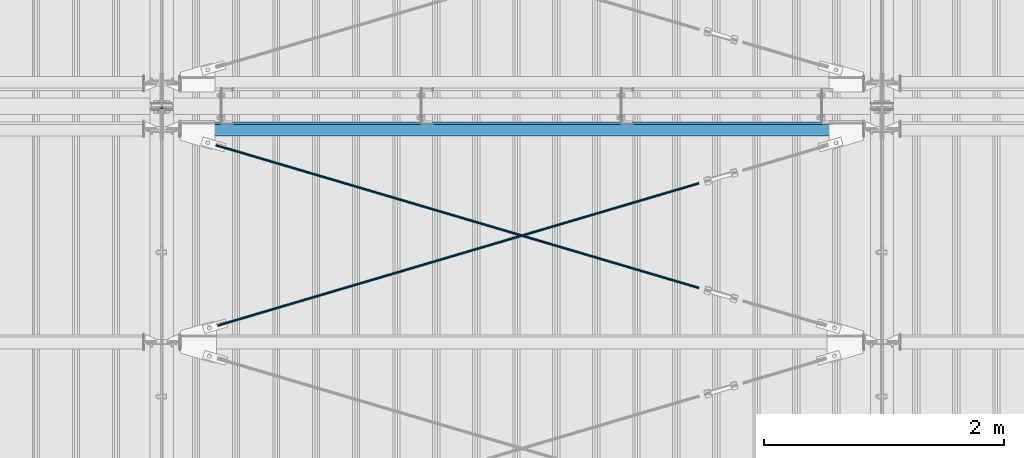
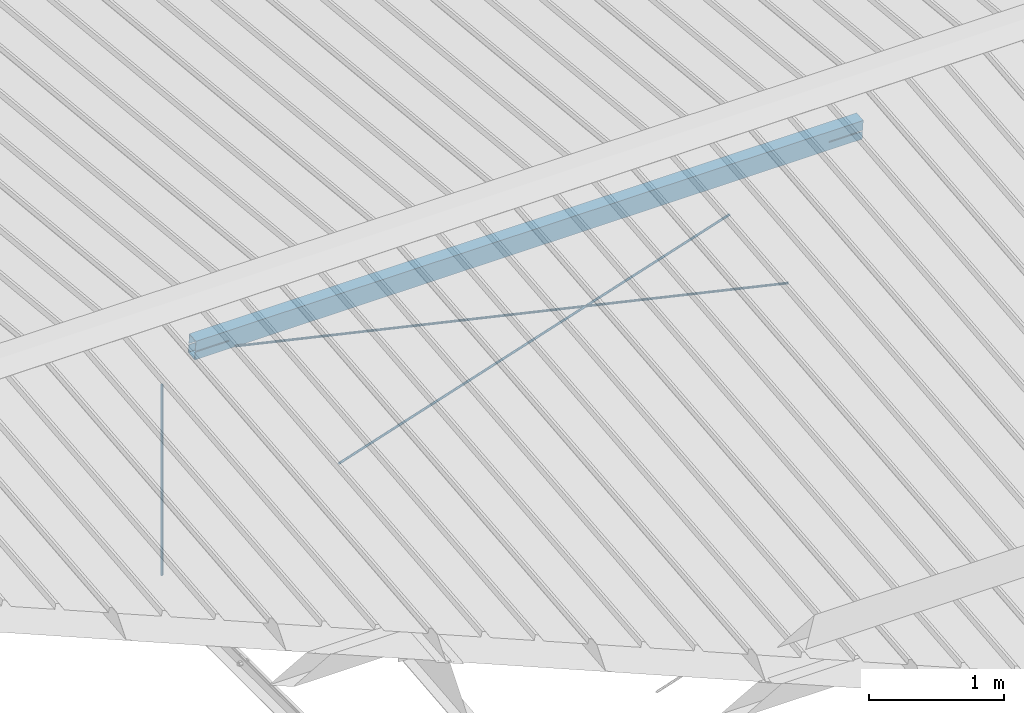
# One storey, part 279 of 709: 4 beams, 4 openings, 4 elements without a shape of their own.
"""IFC4 building model written with IfcOpenShell, lengths in millimetres."""

from ifc_helpers import new_model, si_unit, direction, frame, origin_with_axes, place, context, subcontext, project, spatial, line, indexed_curve, outline, extrude, polygons, material, element, aggregate, save


model = new_model("IFC4")

# Units and contexts
model_context = context("Model", 3, precision=0.2, world=origin_with_axes(), true_north=direction((0.0, 1.0)))
body_context = subcontext(model_context, "Body", "Model", "MODEL_VIEW")
reference_context = subcontext(model_context, "Reference", "Model", "MODEL_VIEW")
ifc_project = project(units=[si_unit("LENGTHUNIT", "METRE", prefix="MILLI"), si_unit("AREAUNIT", "SQUARE_METRE"), si_unit("VOLUMEUNIT", "CUBIC_METRE"), si_unit("MASSUNIT", "GRAM", prefix="KILO"), si_unit("TIMEUNIT", "SECOND"), si_unit("PLANEANGLEUNIT", "RADIAN"), si_unit("SOLIDANGLEUNIT", "STERADIAN"), si_unit("THERMODYNAMICTEMPERATUREUNIT", "DEGREE_CELSIUS"), si_unit("LUMINOUSINTENSITYUNIT", "LUMEN")], contexts=[model_context])

# Site, building, storey
site_placement = place(None, origin_with_axes())
site = spatial("IfcSite", under=ifc_project, at=site_placement, CompositionType="ELEMENT")
building_placement = place(site_placement, origin_with_axes())
building = spatial("IfcBuilding", under=site, at=building_placement, Name="Undefined", CompositionType="ELEMENT")
storey_placement = place(building_placement, origin_with_axes())
storey = spatial("IfcBuildingStorey", under=building, at=storey_placement, Name="Undefined", CompositionType="ELEMENT", Elevation=0.0)

# Assembly, beam
assembly_1_placement = place(storey_placement, frame((40000.0, 10985.0, 8155.10002), z_axis=(0.0, -1.0, 0.0), x_axis=(0.0, 0.0, -1.0)))
assembly_1 = element("IfcElementAssembly", 1, at=assembly_1_placement, inside=storey)
ifc_material_1 = material(Name="C355-5", Category="STEEL")
beam_1_placement = place(assembly_1_placement, origin_with_axes())
beam_1 = element("IfcBeam", 2, at=beam_1_placement, material=ifc_material_1, ObjectType="437", context=body_context, shape_type="Tessellation", body=[
    polygons([(326.36285, 0.0, 10.0), (326.36285, -2.58819, 9.65926), (2045.1, -2.58819, 9.65926), (2045.1, 0.0, 10.0), (326.36285, -5.0, 8.66025), (2045.1, -5.0, 8.66025), (326.36285, -7.07107, 7.07107), (2045.1, -7.07107, 7.07107), (326.36285, -8.66025, 5.0), (2045.1, -8.66025, 5.0), (326.36285, -9.65926, 2.58819), (2045.1, -9.65926, 2.58819), (326.36285, -10.0, 0.0), (2045.1, -10.0, 0.0), (326.36285, -9.65926, -2.58819), (2045.1, -9.65926, -2.58819), (326.36285, -8.66025, -5.0), (2045.1, -8.66025, -5.0), (326.36285, -7.07107, -7.07107), (2045.1, -7.07107, -7.07107), (326.36285, -5.0, -8.66025), (2045.1, -5.0, -8.66025), (326.36285, -2.58819, -9.65926), (2045.1, -2.58819, -9.65926), (326.36285, 0.0, -10.0), (2045.1, 0.0, -10.0), (326.36285, 2.58819, -9.65926), (2045.1, 2.58819, -9.65926), (326.36285, 5.0, -8.66025), (2045.1, 5.0, -8.66025), (326.36285, 7.07107, -7.07107), (2045.1, 7.07107, -7.07107), (326.36285, 8.66025, -5.0), (2045.1, 8.66025, -5.0), (326.36285, 9.65926, -2.58819), (2045.1, 9.65926, -2.58819), (326.36285, 10.0, 0.0), (2045.1, 10.0, 0.0), (326.36285, 9.65926, 2.58819), (2045.1, 9.65926, 2.58819), (326.36285, 8.66025, 5.0), (2045.1, 8.66025, 5.0), (326.36285, 7.07107, 7.07107), (2045.1, 7.07107, 7.07107), (326.36285, 5.0, 8.66025), (2045.1, 5.0, 8.66025), (326.36285, 2.58819, 9.65926), (2045.1, 2.58819, 9.65926)], [[[1, 2, 3, 4]], [[2, 5, 6, 3]], [[5, 7, 8, 6]], [[7, 9, 10, 8]], [[9, 11, 12, 10]], [[11, 13, 14, 12]], [[13, 15, 16, 14]], [[15, 17, 18, 16]], [[17, 19, 20, 18]], [[19, 21, 22, 20]], [[21, 23, 24, 22]], [[23, 25, 26, 24]], [[25, 27, 28, 26]], [[27, 29, 30, 28]], [[29, 31, 32, 30]], [[31, 33, 34, 32]], [[33, 35, 36, 34]], [[35, 37, 38, 36]], [[37, 39, 40, 38]], [[39, 41, 42, 40]], [[41, 43, 44, 42]], [[43, 45, 46, 44]], [[45, 47, 48, 46]], [[47, 1, 4, 48]], [[6, 8, 10, 12, 14, 16, 18, 20, 22, 24, 26, 28, 30, 32, 34, 36, 38, 40, 42, 44, 46, 48, 4, 3]], [[47, 45, 43, 41, 39, 37, 35, 33, 31, 29, 27, 25, 23, 21, 19, 17, 15, 13, 11, 9, 7, 5, 2, 1]]], closed=True),
])
aggregate(assembly_1, [beam_1])

# Assembly, beam, voiding feature
assembly_2_placement = place(storey_placement, frame((40000.0, 9035.85409, 8040.08943), z_axis=(0.2847296511, -0.9538504697, -0.095385047), x_axis=(0.9586078582, 0.2833165921, 0.028331659)))
assembly_2 = element("IfcElementAssembly", 3, at=assembly_2_placement, inside=storey)
beam_2_placement = place(assembly_2_placement, origin_with_axes())
beam_2 = element("IfcBeam", 4, at=beam_2_placement, material=ifc_material_1, ObjectType="572", context=body_context, shape_type="Tessellation", body=[
    polygons([(4849.07659, 7.36122, 4.25), (4849.07659, 6.01041, 6.01041), (4849.07659, 4.25, 7.36122), (4849.07659, 2.19996, 8.21037), (4849.07659, 0.0, 8.5), (4849.07659, -2.19996, 8.21037), (4849.07659, -4.25, 7.36122), (4849.07659, -6.01041, 6.01041), (4849.07659, -7.36121, 4.25), (4849.07659, -8.21037, 2.19996), (4849.07659, -8.5, 0.0), (4849.07659, -8.21037, -2.19996), (4849.07659, -7.36121, -4.25), (4849.07659, -6.01041, -6.01041), (4849.07659, -4.25, -7.36122), (4849.07659, -2.19996, -8.21037), (4849.07659, 0.0, -8.5), (4849.07659, 2.19996, -8.21037), (4849.07659, 4.25, -7.36122), (4849.07659, 6.01041, -6.01041), (4849.07659, 7.36122, -4.25), (4849.07659, 8.21037, -2.19996), (4849.07659, 8.5, 0.0), (4849.07659, 8.21037, 2.19996), (4669.07659, 8.21037, 2.19996), (4669.07659, 7.36122, 4.25), (4669.07659, 6.01041, 6.01041), (4669.07659, 4.25, 7.36122), (4669.07659, 2.19996, 8.21037), (4669.07659, 0.0, 8.5), (4669.07659, -2.19996, 8.21037), (4669.07659, -4.25, 7.36122), (4669.07659, -6.01041, 6.01041), (4669.07659, -7.36121, 4.25), (4669.07659, -8.21037, 2.19996), (4669.07659, -8.5, 0.0), (4669.07659, -8.21037, -2.19996), (4669.07659, -7.36121, -4.25), (4669.07659, -6.01041, -6.01041), (4669.07659, -4.25, -7.36122), (4669.07659, -2.19996, -8.21037), (4669.07659, 0.0, -8.5), (4669.07659, 2.19996, -8.21037), (4669.07659, 4.25, -7.36122), (4669.07659, 6.01041, -6.01041), (4669.07659, 7.36122, -4.25), (4669.07659, 8.21037, -2.19996), (4669.07659, 8.5, 0.0), (4669.07659, 10.0, 0.0), (4669.07659, 9.65926, 2.58819), (4669.07659, 8.66025, 5.0), (4669.07659, 7.07107, 7.07107), (4669.07659, 5.0, 8.66025), (4669.07659, 2.58819, 9.65926), (4669.07659, 0.0, 10.0), (4669.07659, -2.58819, 9.65926), (4669.07659, -5.0, 8.66025), (4669.07659, -7.07107, 7.07107), (4669.07659, -8.66025, 5.0), (4669.07659, -9.65926, 2.58819), (4669.07659, -10.0, 0.0), (4669.07659, -9.65926, -2.58819), (4669.07659, -8.66025, -5.0), (4669.07659, -7.07107, -7.07107), (4669.07659, -5.0, -8.66025), (4669.07659, -2.58819, -9.65926), (4669.07659, 0.0, -10.0), (4669.07659, 2.58819, -9.65926), (4669.07659, 5.0, -8.66025), (4669.07659, 7.07107, -7.07107), (4669.07659, 8.66025, -5.0), (4669.07659, 9.65926, -2.58819), (483.68279, 2.58819, 9.65926), (483.68279, 5.0, 8.66025), (483.68279, 7.07107, 7.07107), (483.68279, 8.66025, 5.0), (483.68279, 9.65926, 2.58819), (483.68279, 10.0, 0.0), (483.68279, 9.65926, -2.58819), (483.68279, 8.66025, -5.0), (483.68279, 7.07107, -7.07107), (483.68279, 5.0, -8.66025), (483.68279, 2.58819, -9.65926), (483.68279, 0.0, -10.0), (483.68279, -2.58819, -9.65926), (483.68279, -5.0, -8.66025), (483.68279, -7.07107, -7.07107), (483.68279, -8.66025, -5.0), (483.68279, -9.65926, -2.58819), (483.68279, -10.0, 0.0), (483.68279, -9.65926, 2.58819), (483.68279, -8.66025, 5.0), (483.68279, -7.07107, 7.07107), (483.68279, -5.0, 8.66025), (483.68279, -2.58819, 9.65926), (483.68279, 0.0, 10.0)], [[[1, 2, 3, 4, 5, 6, 7, 8, 9, 10, 11, 12, 13, 14, 15, 16, 17, 18, 19, 20, 21, 22, 23, 24]], [[24, 25, 26, 1]], [[1, 26, 27, 2]], [[2, 27, 28, 3]], [[3, 28, 29, 4]], [[4, 29, 30, 5]], [[5, 30, 31, 6]], [[6, 31, 32, 7]], [[7, 32, 33, 8]], [[8, 33, 34, 9]], [[9, 34, 35, 10]], [[10, 35, 36, 11]], [[11, 36, 37, 12]], [[12, 37, 38, 13]], [[13, 38, 39, 14]], [[14, 39, 40, 15]], [[15, 40, 41, 16]], [[16, 41, 42, 17]], [[17, 42, 43, 18]], [[18, 43, 44, 19]], [[19, 44, 45, 20]], [[20, 45, 46, 21]], [[21, 46, 47, 22]], [[22, 47, 48, 23]], [[23, 48, 25, 24]], [[49, 50, 51, 52, 53, 54, 55, 56, 57, 58, 59, 60, 61, 62, 63, 64, 65, 66, 67, 68, 69, 70, 71, 72], [47, 46, 45, 44, 43, 42, 41, 40, 39, 38, 37, 36, 35, 34, 33, 32, 31, 30, 29, 28, 27, 26, 25, 48]], [[73, 74, 75, 76, 77, 78, 79, 80, 81, 82, 83, 84, 85, 86, 87, 88, 89, 90, 91, 92, 93, 94, 95, 96]], [[79, 78, 49, 72]], [[80, 79, 72, 71]], [[81, 80, 71, 70]], [[82, 81, 70, 69]], [[83, 82, 69, 68]], [[84, 83, 68, 67]], [[85, 84, 67, 66]], [[86, 85, 66, 65]], [[87, 86, 65, 64]], [[88, 87, 64, 63]], [[89, 88, 63, 62]], [[90, 89, 62, 61]], [[91, 90, 61, 60]], [[92, 91, 60, 59]], [[93, 92, 59, 58]], [[94, 93, 58, 57]], [[95, 94, 57, 56]], [[96, 95, 56, 55]], [[73, 96, 55, 54]], [[74, 73, 54, 53]], [[75, 74, 53, 52]], [[76, 75, 52, 51]], [[77, 76, 51, 50]], [[78, 77, 50, 49]]], closed=True),
])
voiding_feature_1_placement = place(beam_2_placement, frame((4849.07659, 0.0, 0.0), z_axis=(0.0, 1.0, 0.0), x_axis=(-1.0, 0.0, 0.0)))
element("IfcVoidingFeature", 5, at=voiding_feature_1_placement, cuts=beam_2, PredefinedType="HOLE", context=reference_context, identifier="Reference", shape_type="SolidModel", body=[
    extrude(outline(indexed_curve([(10.5, 0.0), (10.14222, 2.7176), (9.09327, 5.25), (7.42462, 7.42462), (5.25, 9.09327), (2.7176, 10.14222), (0.0, 10.5), (-2.7176, 10.14222), (-5.25, 9.09327), (-7.42462, 7.42462), (-9.09327, 5.25), (-10.14222, 2.7176), (-10.5, 0.0), (-10.14222, -2.7176), (-9.09327, -5.25), (-7.42462, -7.42462), (-5.25, -9.09327), (-2.7176, -10.14222), (0.0, -10.5), (2.7176, -10.14222), (5.25, -9.09327), (7.42462, -7.42462), (9.09327, -5.25), (10.14222, -2.7176)], segments=[line(1, 2, 3, 4, 5, 6, 7, 8, 9, 10, 11, 12, 13, 14, 15, 16, 17, 18, 19, 20, 21, 22, 23, 24, 1)])), frame((0.0, 0.0, 0.0), z_axis=(-1.0, 0.0, 0.0), x_axis=(0.0, 0.0, 1.0)), (0.0, 0.0, -1.0), 180.0),
])
aggregate(assembly_2, [beam_2])

assembly_3_placement = place(storey_placement, frame((40000.0, 10809.15434, 8217.41945), z_axis=(-0.2847296511, -0.9538504697, -0.095385047), x_axis=(0.9586078582, -0.2833165921, -0.028331659)))
assembly_3 = element("IfcElementAssembly", 6, at=assembly_3_placement, inside=storey)
beam_3_placement = place(assembly_3_placement, origin_with_axes())
beam_3 = element("IfcBeam", 7, at=beam_3_placement, material=ifc_material_1, ObjectType="573", context=body_context, shape_type="Tessellation", body=[
    polygons([(4849.07659, 7.36121, 4.25), (4849.07659, 6.01041, 6.01041), (4849.07659, 4.25, 7.36122), (4849.07659, 2.19996, 8.21037), (4849.07659, 0.0, 8.5), (4849.07659, -2.19996, 8.21037), (4849.07659, -4.25, 7.36122), (4849.07659, -6.01041, 6.01041), (4849.07659, -7.36122, 4.25), (4849.07659, -8.21037, 2.19996), (4849.07659, -8.5, 0.0), (4849.07659, -8.21037, -2.19996), (4849.07659, -7.36122, -4.25), (4849.07659, -6.01041, -6.01041), (4849.07659, -4.25, -7.36122), (4849.07659, -2.19996, -8.21037), (4849.07659, 0.0, -8.5), (4849.07659, 2.19996, -8.21037), (4849.07659, 4.25, -7.36122), (4849.07659, 6.01041, -6.01041), (4849.07659, 7.36121, -4.25), (4849.07659, 8.21037, -2.19996), (4849.07659, 8.5, 0.0), (4849.07659, 8.21037, 2.19996), (4669.07659, 8.21037, 2.19996), (4669.07659, 7.36121, 4.25), (4669.07659, 6.01041, 6.01041), (4669.07659, 4.25, 7.36122), (4669.07659, 2.19996, 8.21037), (4669.07659, 0.0, 8.5), (4669.07659, -2.19996, 8.21037), (4669.07659, -4.25, 7.36122), (4669.07659, -6.01041, 6.01041), (4669.07659, -7.36122, 4.25), (4669.07659, -8.21037, 2.19996), (4669.07659, -8.5, 0.0), (4669.07659, -8.21037, -2.19996), (4669.07659, -7.36122, -4.25), (4669.07659, -6.01041, -6.01041), (4669.07659, -4.25, -7.36122), (4669.07659, -2.19996, -8.21037), (4669.07659, 0.0, -8.5), (4669.07659, 2.19996, -8.21037), (4669.07659, 4.25, -7.36122), (4669.07659, 6.01041, -6.01041), (4669.07659, 7.36121, -4.25), (4669.07659, 8.21037, -2.19996), (4669.07659, 8.5, 0.0), (4669.07659, 10.0, 0.0), (4669.07659, 9.65926, 2.58819), (4669.07659, 8.66025, 5.0), (4669.07659, 7.07107, 7.07107), (4669.07659, 5.0, 8.66025), (4669.07659, 2.58819, 9.65926), (4669.07659, 0.0, 10.0), (4669.07659, -2.58819, 9.65926), (4669.07659, -5.0, 8.66025), (4669.07659, -7.07107, 7.07107), (4669.07659, -8.66025, 5.0), (4669.07659, -9.65926, 2.58819), (4669.07659, -10.0, 0.0), (4669.07659, -9.65926, -2.58819), (4669.07659, -8.66025, -5.0), (4669.07659, -7.07107, -7.07107), (4669.07659, -5.0, -8.66025), (4669.07659, -2.58819, -9.65926), (4669.07659, 0.0, -10.0), (4669.07659, 2.58819, -9.65926), (4669.07659, 5.0, -8.66025), (4669.07659, 7.07107, -7.07107), (4669.07659, 8.66025, -5.0), (4669.07659, 9.65926, -2.58819), (468.68279, 2.58819, 9.65926), (468.68279, 5.0, 8.66025), (468.68279, 7.07107, 7.07107), (468.68279, 8.66025, 5.0), (468.68279, 9.65926, 2.58819), (468.68279, 10.0, 0.0), (468.68279, 9.65926, -2.58819), (468.68279, 8.66025, -5.0), (468.68279, 7.07107, -7.07107), (468.68279, 5.0, -8.66025), (468.68279, 2.58819, -9.65926), (468.68279, 0.0, -10.0), (468.68279, -2.58819, -9.65926), (468.68279, -5.0, -8.66025), (468.68279, -7.07107, -7.07107), (468.68279, -8.66025, -5.0), (468.68279, -9.65926, -2.58819), (468.68279, -10.0, 0.0), (468.68279, -9.65926, 2.58819), (468.68279, -8.66025, 5.0), (468.68279, -7.07107, 7.07107), (468.68279, -5.0, 8.66025), (468.68279, -2.58819, 9.65926), (468.68279, 0.0, 10.0)], [[[1, 2, 3, 4, 5, 6, 7, 8, 9, 10, 11, 12, 13, 14, 15, 16, 17, 18, 19, 20, 21, 22, 23, 24]], [[24, 25, 26, 1]], [[1, 26, 27, 2]], [[2, 27, 28, 3]], [[3, 28, 29, 4]], [[4, 29, 30, 5]], [[5, 30, 31, 6]], [[6, 31, 32, 7]], [[7, 32, 33, 8]], [[8, 33, 34, 9]], [[9, 34, 35, 10]], [[10, 35, 36, 11]], [[11, 36, 37, 12]], [[12, 37, 38, 13]], [[13, 38, 39, 14]], [[14, 39, 40, 15]], [[15, 40, 41, 16]], [[16, 41, 42, 17]], [[17, 42, 43, 18]], [[18, 43, 44, 19]], [[19, 44, 45, 20]], [[20, 45, 46, 21]], [[21, 46, 47, 22]], [[22, 47, 48, 23]], [[23, 48, 25, 24]], [[49, 50, 51, 52, 53, 54, 55, 56, 57, 58, 59, 60, 61, 62, 63, 64, 65, 66, 67, 68, 69, 70, 71, 72], [47, 46, 45, 44, 43, 42, 41, 40, 39, 38, 37, 36, 35, 34, 33, 32, 31, 30, 29, 28, 27, 26, 25, 48]], [[73, 74, 75, 76, 77, 78, 79, 80, 81, 82, 83, 84, 85, 86, 87, 88, 89, 90, 91, 92, 93, 94, 95, 96]], [[79, 78, 49, 72]], [[80, 79, 72, 71]], [[81, 80, 71, 70]], [[82, 81, 70, 69]], [[83, 82, 69, 68]], [[84, 83, 68, 67]], [[85, 84, 67, 66]], [[86, 85, 66, 65]], [[87, 86, 65, 64]], [[88, 87, 64, 63]], [[89, 88, 63, 62]], [[90, 89, 62, 61]], [[91, 90, 61, 60]], [[92, 91, 60, 59]], [[93, 92, 59, 58]], [[94, 93, 58, 57]], [[95, 94, 57, 56]], [[96, 95, 56, 55]], [[73, 96, 55, 54]], [[74, 73, 54, 53]], [[75, 74, 53, 52]], [[76, 75, 52, 51]], [[77, 76, 51, 50]], [[78, 77, 50, 49]]], closed=True),
])
voiding_feature_2_placement = place(beam_3_placement, frame((4849.07659, 0.0, 0.0), z_axis=(0.0, 1.0, 0.0), x_axis=(-1.0, 0.0, 0.0)))
element("IfcVoidingFeature", 8, at=voiding_feature_2_placement, cuts=beam_3, PredefinedType="HOLE", context=reference_context, identifier="Reference", shape_type="SolidModel", body=[
    extrude(outline(indexed_curve([(10.5, 0.0), (10.14222, 2.7176), (9.09327, 5.25), (7.42462, 7.42462), (5.25, 9.09327), (2.7176, 10.14222), (0.0, 10.5), (-2.7176, 10.14222), (-5.25, 9.09327), (-7.42462, 7.42462), (-9.09327, 5.25), (-10.14222, 2.7176), (-10.5, 0.0), (-10.14222, -2.7176), (-9.09327, -5.25), (-7.42462, -7.42462), (-5.25, -9.09327), (-2.7176, -10.14222), (0.0, -10.5), (2.7176, -10.14222), (5.25, -9.09327), (7.42462, -7.42462), (9.09327, -5.25), (10.14222, -2.7176)], segments=[line(1, 2, 3, 4, 5, 6, 7, 8, 9, 10, 11, 12, 13, 14, 15, 16, 17, 18, 19, 20, 21, 22, 23, 24, 1)])), frame((0.0, 0.0, 0.0), z_axis=(-1.0, 0.0, 0.0), x_axis=(0.0, 0.0, 1.0)), (0.0, 0.0, -1.0), 180.0),
])
aggregate(assembly_3, [beam_3])

# Assembly, beam, voiding features
assembly_4_placement = place(storey_placement, frame((40000.0, 10808.95533, 8219.40952), z_axis=(0.0, 0.9950371902, 0.099503719), x_axis=(1.0, 0.0, 0.0)))
assembly_4 = element("IfcElementAssembly", 9, at=assembly_4_placement, inside=storey)
ifc_material_2 = material(Name="C355", Category="STEEL")
beam_4_placement = place(assembly_4_placement, origin_with_axes())
beam_4 = element("IfcBeam", 10, at=beam_4_placement, material=ifc_material_2, ObjectType="567", context=body_context, shape_type="Tessellation", body=[
    polygons([(442.92369, 5.0, 50.0), (442.92369, 5.0, 46.0), (155.0, 5.0, 46.0), (155.0, 5.0, 50.0), (442.92369, 15.0, 50.0), (442.92369, 15.0, 46.0), (155.0, 15.0, 50.0), (155.0, 15.0, 46.0), (442.92369, 5.0, -46.0), (442.92369, 5.0, -50.0), (155.0, 5.0, -50.0), (155.0, 5.0, -46.0), (442.92369, 15.0, -46.0), (442.92369, 15.0, -50.0), (155.0, 15.0, -46.0), (155.0, 15.0, -50.0), (155.0, 86.0, 46.0), (155.0, 86.0, -46.0), (5845.0, 86.0, -46.0), (5845.0, 86.0, 46.0), (155.0, 90.0, -50.0), (5845.0, 90.0, -50.0), (5845.0, 15.0, -50.0), (5557.07631, 15.0, -50.0), (5557.07631, 5.0, -50.0), (5845.0, 5.0, -50.0), (5845.0, -90.0, -50.0), (155.0, -90.0, -50.0), (5845.0, 15.0, -46.0), (5557.07631, 15.0, -46.0), (5557.07631, 5.0, -46.0), (5845.0, 5.0, -46.0), (155.0, -86.0, -46.0), (155.0, -86.0, 46.0), (5845.0, -86.0, 46.0), (5845.0, -86.0, -46.0), (5557.07631, 5.0, 50.0), (5557.07631, 5.0, 46.0), (5557.07631, 15.0, 46.0), (5557.07631, 15.0, 50.0), (5845.0, 5.0, 50.0), (5845.0, 5.0, 46.0), (5845.0, -90.0, 50.0), (155.0, -90.0, 50.0), (5845.0, 15.0, 46.0), (5845.0, 15.0, 50.0), (5845.0, 90.0, 50.0), (155.0, 90.0, 50.0)], [[[1, 2, 3, 4]], [[5, 6, 2, 1]], [[7, 8, 6, 5]], [[9, 10, 11, 12]], [[13, 14, 10, 9]], [[15, 16, 14, 13]], [[17, 18, 19, 20]], [[21, 22, 23, 24, 25, 26, 27, 28, 11, 10, 14, 16]], [[29, 30, 24, 23]], [[31, 25, 24, 30]], [[32, 26, 25, 31]], [[33, 34, 35, 36]], [[37, 38, 39, 40]], [[41, 42, 38, 37]], [[43, 27, 26, 32, 36, 35, 42, 41]], [[44, 28, 27, 43]], [[34, 33, 12, 11, 28, 44, 4, 3]], [[17, 20, 45, 39, 38, 42, 35, 34, 3, 2, 6, 8]], [[46, 40, 39, 45]], [[20, 19, 29, 23, 22, 47, 46, 45]], [[21, 48, 47, 22]], [[4, 44, 43, 41, 37, 40, 46, 47, 48, 7, 5, 1]], [[48, 21, 16, 15, 18, 17, 8, 7]], [[12, 33, 36, 32, 31, 30, 29, 19, 18, 15, 13, 9]]], closed=True),
])
voiding_feature_3_placement = place(beam_4_placement, frame((5845.0, 10.0, 70.0), z_axis=(0.0, -1.0, 0.0), x_axis=(-1.0, 0.0, 0.0)))
element("IfcVoidingFeature", 11, at=voiding_feature_3_placement, cuts=beam_4, PredefinedType="HOLE", context=reference_context, identifier="Reference", shape_type="SolidModel", body=[
    extrude(outline(indexed_curve([(0.0, 0.0), (287.92369, 0.0), (287.92369, 154.61594), (262.29802, 240.89065), (0.0, 162.98181)], segments=[line(1, 2, 3, 4, 5, 1)])), frame((0.0, 0.0, 5.0), z_axis=(0.0, 0.0, 1.0), x_axis=(1.0, 0.0, 0.0)), (0.0, 0.0, -1.0), 10.0),
])
voiding_feature_4_placement = place(beam_4_placement, frame((442.92369, 10.0, 70.0), z_axis=(0.0, -1.0, 0.0), x_axis=(-1.0, 0.0, 0.0)))
element("IfcVoidingFeature", 12, at=voiding_feature_4_placement, cuts=beam_4, PredefinedType="HOLE", context=reference_context, identifier="Reference", shape_type="SolidModel", body=[
    extrude(outline(indexed_curve([(0.0, 0.0), (287.92369, 0.0), (287.92369, 162.98181), (25.62567, 240.89065), (0.0, 154.61594)], segments=[line(1, 2, 3, 4, 5, 1)])), frame((0.0, 0.0, 5.0), z_axis=(0.0, 0.0, 1.0), x_axis=(1.0, 0.0, 0.0)), (0.0, 0.0, -1.0), 10.0),
])
aggregate(assembly_4, [beam_4])

save(model, "model.ifc")
